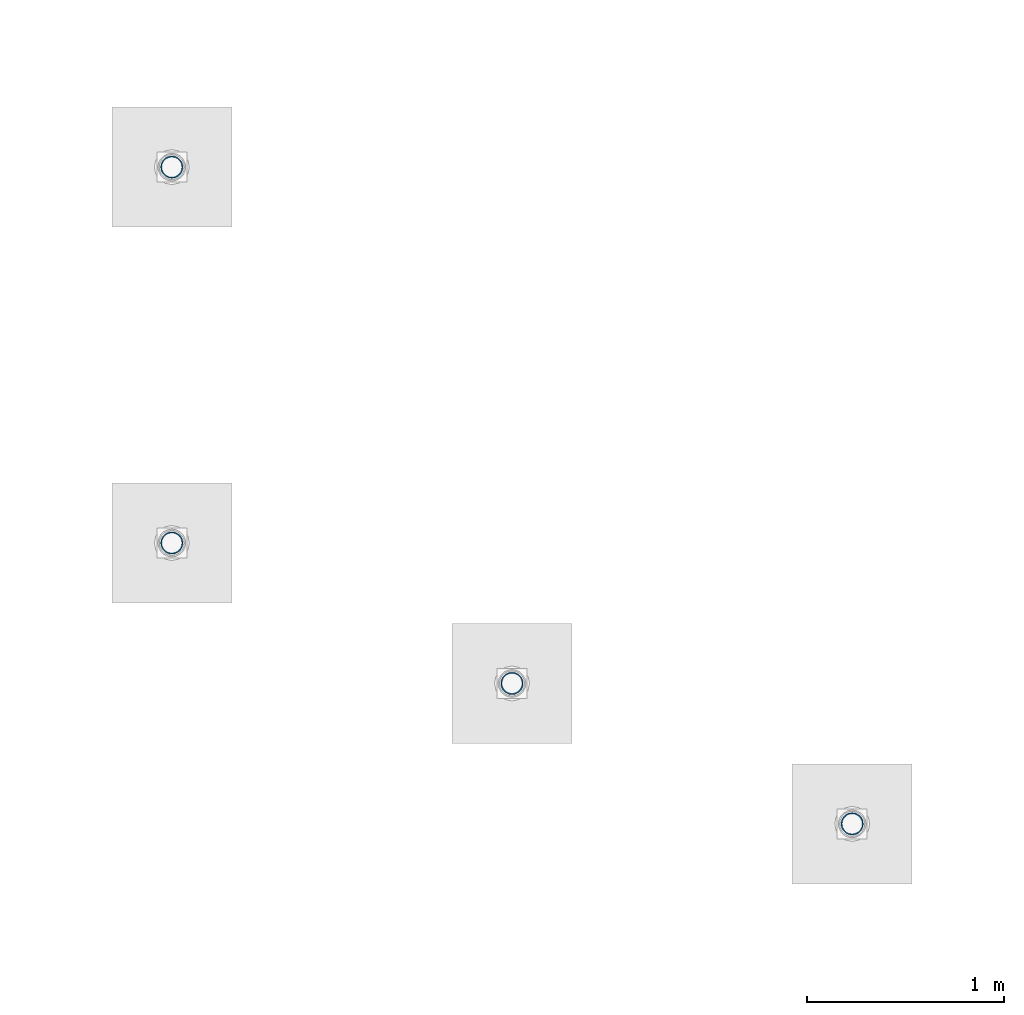
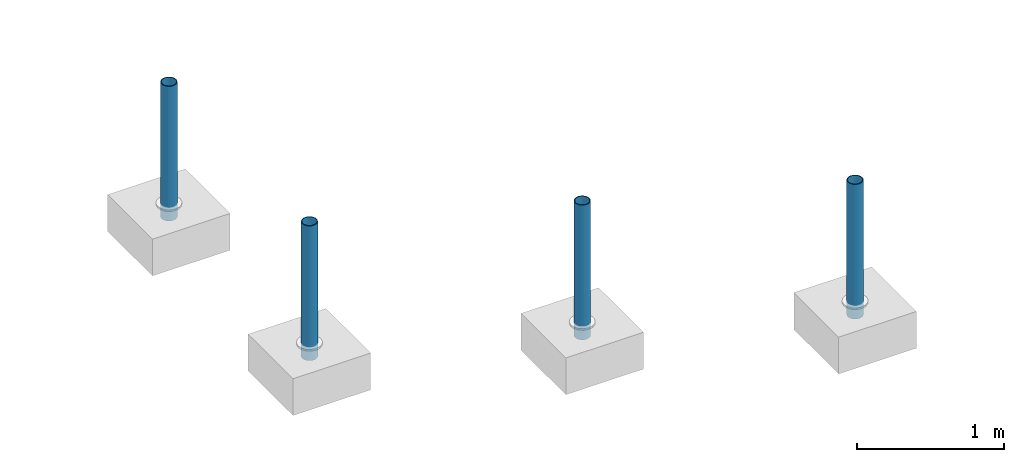
# One storey, part 1274 of 3843: 4 columns, 4 elements without a shape of their own.
"""IFC2X3 building model written with IfcOpenShell, lengths in millimetres."""

from ifc_helpers import new_model, si_unit, frame, origin_with_axes, place, context, subcontext, project, spatial, faceted_brep, material, type_object, element, aggregate, save


model = new_model("IFC2X3")

# Units and contexts
model_context = context("Model", 3, precision=1e-05, world=origin_with_axes())
body_context = subcontext(model_context, "Body", "Model", "MODEL_VIEW")
ifc_project = project(units=[si_unit("LENGTHUNIT", "METRE", prefix="MILLI"), si_unit("AREAUNIT", "SQUARE_METRE"), si_unit("VOLUMEUNIT", "CUBIC_METRE"), si_unit("MASSUNIT", "GRAM", prefix="KILO"), si_unit("TIMEUNIT", "SECOND"), si_unit("PLANEANGLEUNIT", "RADIAN"), si_unit("SOLIDANGLEUNIT", "STERADIAN"), si_unit("THERMODYNAMICTEMPERATUREUNIT", "DEGREE_CELSIUS"), si_unit("LUMINOUSINTENSITYUNIT", "LUMEN")], contexts=[model_context])

# Site, building, storey
site_placement = place(None, origin_with_axes())
site = spatial("IfcSite", under=ifc_project, at=site_placement, CompositionType="ELEMENT")
building_placement = place(site_placement, origin_with_axes())
building = spatial("IfcBuilding", under=site, at=building_placement, Name="Undefined", CompositionType="ELEMENT")
storey_placement = place(building_placement, origin_with_axes())
storey = spatial("IfcBuildingStorey", under=building, at=storey_placement, Name="Undefined", CompositionType="ELEMENT", Elevation=0.0)

# Assembly, column
assembly_1_placement = place(storey_placement, origin_with_axes())
assembly_1 = element("IfcElementAssembly", 1, at=assembly_1_placement, inside=storey, Name="PIPE_BOLLARD", AssemblyPlace="NOTDEFINED", PredefinedType="RIGID_FRAME")
ifc_material = material()
column_type = type_object("IfcColumnType", Name="PIPE4SCH40", PredefinedType="NOTDEFINED")
column_1_placement = place(assembly_1_placement, frame((-13010.053650111, 36218.2505800724, 30378.4), z_axis=(-1.0, 0.0, 0.0), x_axis=(0.0, 0.0, 1.0)))
column_1 = element("IfcColumn", 2, at=column_1_placement, type_object=column_type, material=ifc_material, Name="PIPE_BOLLARD", ObjectType="PIPE4SCH40", context=body_context, shape_type="Brep", body=[
    faceted_brep([(0.0, -51.1301999999996, 0.0), (0.0, -48.6277098894743, 15.8001007257844), (1117.6, -48.6277098894743, 15.8001007257844), (1117.6, -51.1301999999996, 0.0), (0.0, -41.3652007257897, 30.0535775067692), (1117.6, -41.3652007257897, 30.0535775067692), (0.0, -30.0535775067647, 41.3652007257915), (1117.6, -30.0535775067647, 41.3652007257915), (0.0, -15.8001007257899, 48.6277098894789), (1117.6, -15.8001007257899, 48.6277098894789), (0.0, 0.0, 51.1301999999996), (1117.6, 0.0, 51.1301999999996), (0.0, 15.8001007257899, 48.6277098894789), (1117.6, 15.8001007257899, 48.6277098894789), (0.0, 30.0535775067647, 41.3652007257915), (1117.6, 30.0535775067647, 41.3652007257915), (0.0, 41.3652007257897, 30.0535775067692), (1117.6, 41.3652007257897, 30.0535775067692), (0.0, 48.6277098894743, 15.8001007257844), (1117.6, 48.6277098894743, 15.8001007257844), (0.0, 51.1301999999996, 0.0), (1117.6, 51.1301999999996, 0.0), (0.0, 48.6277098894743, -15.8001007257844), (1117.6, 48.6277098894743, -15.8001007257844), (0.0, 41.3652007257897, -30.0535775067692), (1117.6, 41.3652007257897, -30.0535775067692), (0.0, 30.0535775067647, -41.3652007257915), (1117.6, 30.0535775067647, -41.3652007257915), (0.0, 15.8001007257899, -48.6277098894789), (1117.6, 15.8001007257899, -48.6277098894789), (0.0, 0.0, -51.1301999999996), (1117.6, 0.0, -51.1301999999996), (0.0, -15.8001007257899, -48.6277098894789), (1117.6, -15.8001007257899, -48.6277098894789), (0.0, -30.0535775067647, -41.3652007257915), (1117.6, -30.0535775067647, -41.3652007257915), (0.0, -41.3652007257897, -30.0535775067692), (1117.6, -41.3652007257897, -30.0535775067692), (0.0, -48.6277098894743, -15.8001007257844), (1117.6, -48.6277098894743, -15.8001007257844), (0.0, -57.1499999999996, 0.0), (0.0, -54.3528799062678, -17.6603212285263), (1117.6, -54.3528799062678, -17.6603212285263), (1117.6, -57.1499999999996, 0.0), (0.0, -46.2353212285279, -33.5919271685125), (1117.6, -46.2353212285279, -33.5919271685125), (0.0, -33.5919271685152, -46.2353212285234), (1117.6, -33.5919271685152, -46.2353212285234), (0.0, -17.6603212285281, -54.3528799062624), (1117.6, -17.6603212285281, -54.3528799062624), (0.0, 0.0, -57.1499999999942), (1117.6, 0.0, -57.1499999999942), (0.0, 17.6603212285281, -54.3528799062624), (1117.6, 17.6603212285281, -54.3528799062624), (0.0, 33.5919271685152, -46.2353212285234), (1117.6, 33.5919271685152, -46.2353212285234), (0.0, 46.2353212285279, -33.5919271685125), (1117.6, 46.2353212285279, -33.5919271685125), (0.0, 54.3528799062678, -17.6603212285263), (1117.6, 54.3528799062678, -17.6603212285263), (0.0, 57.1499999999996, 0.0), (1117.6, 57.1499999999996, 0.0), (0.0, 54.3528799062678, 17.6603212285263), (1117.6, 54.3528799062678, 17.6603212285263), (0.0, 46.2353212285279, 33.5919271685125), (1117.6, 46.2353212285279, 33.5919271685125), (0.0, 33.5919271685152, 46.2353212285234), (1117.6, 33.5919271685152, 46.2353212285234), (0.0, 17.6603212285281, 54.3528799062624), (1117.6, 17.6603212285281, 54.3528799062624), (0.0, 0.0, 57.1499999999942), (1117.6, 0.0, 57.1499999999942), (0.0, -17.6603212285281, 54.3528799062624), (1117.6, -17.6603212285281, 54.3528799062624), (0.0, -33.5919271685152, 46.2353212285234), (1117.6, -33.5919271685152, 46.2353212285234), (0.0, -46.2353212285279, 33.5919271685125), (1117.6, -46.2353212285279, 33.5919271685125), (0.0, -54.3528799062678, 17.6603212285263), (1117.6, -54.3528799062678, 17.6603212285263)], [[[0, 1, 2, 3]], [[1, 4, 5, 2]], [[4, 6, 7, 5]], [[6, 8, 9, 7]], [[8, 10, 11, 9]], [[10, 12, 13, 11]], [[12, 14, 15, 13]], [[14, 16, 17, 15]], [[16, 18, 19, 17]], [[18, 20, 21, 19]], [[20, 22, 23, 21]], [[22, 24, 25, 23]], [[24, 26, 27, 25]], [[26, 28, 29, 27]], [[28, 30, 31, 29]], [[30, 32, 33, 31]], [[32, 34, 35, 33]], [[34, 36, 37, 35]], [[36, 38, 39, 37]], [[38, 0, 3, 39]], [[40, 41, 42, 43]], [[41, 44, 45, 42]], [[44, 46, 47, 45]], [[46, 48, 49, 47]], [[48, 50, 51, 49]], [[50, 52, 53, 51]], [[52, 54, 55, 53]], [[54, 56, 57, 55]], [[56, 58, 59, 57]], [[58, 60, 61, 59]], [[60, 62, 63, 61]], [[62, 64, 65, 63]], [[64, 66, 67, 65]], [[66, 68, 69, 67]], [[68, 70, 71, 69]], [[70, 72, 73, 71]], [[72, 74, 75, 73]], [[74, 76, 77, 75]], [[76, 78, 79, 77]], [[78, 40, 43, 79]], [[45, 47, 49, 51, 53, 55, 57, 59, 61, 63, 65, 67, 69, 71, 73, 75, 77, 79, 43, 42], [5, 7, 9, 11, 13, 15, 17, 19, 21, 23, 25, 27, 29, 31, 33, 35, 37, 39, 3, 2]], [[78, 76, 74, 72, 70, 68, 66, 64, 62, 60, 58, 56, 54, 52, 50, 48, 46, 44, 41, 40], [38, 36, 34, 32, 30, 28, 26, 24, 22, 20, 18, 16, 14, 12, 10, 8, 6, 4, 1, 0]]]),
])
aggregate(assembly_1, [column_1])

assembly_2_placement = place(storey_placement, origin_with_axes())
assembly_2 = element("IfcElementAssembly", 3, at=assembly_2_placement, inside=storey, Name="PIPE_BOLLARD", AssemblyPlace="NOTDEFINED", PredefinedType="RIGID_FRAME")
column_2_placement = place(assembly_2_placement, frame((-14738.8916170299, 36932.010956049, 30378.4), z_axis=(-1.0, 0.0, 0.0), x_axis=(0.0, 0.0, 1.0)))
column_2 = element("IfcColumn", 4, at=column_2_placement, type_object=column_type, material=ifc_material, Name="PIPE_BOLLARD", ObjectType="PIPE4SCH40", context=body_context, shape_type="Brep", body=[
    faceted_brep([(0.0, -51.1301999999996, 0.0), (0.0, -48.6277098894743, 15.8001007257844), (1117.6, -48.6277098894743, 15.8001007257844), (1117.6, -51.1301999999996, 0.0), (0.0, -41.3652007257897, 30.0535775067692), (1117.6, -41.3652007257897, 30.0535775067692), (0.0, -30.0535775067647, 41.3652007257915), (1117.6, -30.0535775067647, 41.3652007257915), (0.0, -15.8001007257899, 48.6277098894789), (1117.6, -15.8001007257899, 48.6277098894789), (0.0, 0.0, 51.1301999999996), (1117.6, 0.0, 51.1301999999996), (0.0, 15.8001007257899, 48.6277098894789), (1117.6, 15.8001007257899, 48.6277098894789), (0.0, 30.0535775067647, 41.3652007257915), (1117.6, 30.0535775067647, 41.3652007257915), (0.0, 41.3652007257897, 30.0535775067692), (1117.6, 41.3652007257897, 30.0535775067692), (0.0, 48.6277098894743, 15.8001007257844), (1117.6, 48.6277098894743, 15.8001007257844), (0.0, 51.1301999999996, 0.0), (1117.6, 51.1301999999996, 0.0), (0.0, 48.6277098894743, -15.8001007257844), (1117.6, 48.6277098894743, -15.8001007257844), (0.0, 41.3652007257897, -30.0535775067692), (1117.6, 41.3652007257897, -30.0535775067692), (0.0, 30.0535775067647, -41.3652007257915), (1117.6, 30.0535775067647, -41.3652007257915), (0.0, 15.8001007257899, -48.6277098894789), (1117.6, 15.8001007257899, -48.6277098894789), (0.0, 0.0, -51.1301999999996), (1117.6, 0.0, -51.1301999999996), (0.0, -15.8001007257899, -48.6277098894789), (1117.6, -15.8001007257899, -48.6277098894789), (0.0, -30.0535775067647, -41.3652007257915), (1117.6, -30.0535775067647, -41.3652007257915), (0.0, -41.3652007257897, -30.0535775067692), (1117.6, -41.3652007257897, -30.0535775067692), (0.0, -48.6277098894743, -15.8001007257844), (1117.6, -48.6277098894743, -15.8001007257844), (0.0, -57.1499999999996, 0.0), (0.0, -54.3528799062678, -17.6603212285263), (1117.6, -54.3528799062678, -17.6603212285263), (1117.6, -57.1499999999996, 0.0), (0.0, -46.2353212285279, -33.5919271685125), (1117.6, -46.2353212285279, -33.5919271685125), (0.0, -33.5919271685152, -46.2353212285234), (1117.6, -33.5919271685152, -46.2353212285234), (0.0, -17.6603212285281, -54.3528799062624), (1117.6, -17.6603212285281, -54.3528799062624), (0.0, 0.0, -57.1499999999942), (1117.6, 0.0, -57.1499999999942), (0.0, 17.6603212285281, -54.3528799062624), (1117.6, 17.6603212285281, -54.3528799062624), (0.0, 33.5919271685152, -46.2353212285234), (1117.6, 33.5919271685152, -46.2353212285234), (0.0, 46.2353212285279, -33.5919271685125), (1117.6, 46.2353212285279, -33.5919271685125), (0.0, 54.3528799062678, -17.6603212285263), (1117.6, 54.3528799062678, -17.6603212285263), (0.0, 57.1499999999996, 0.0), (1117.6, 57.1499999999996, 0.0), (0.0, 54.3528799062678, 17.6603212285263), (1117.6, 54.3528799062678, 17.6603212285263), (0.0, 46.2353212285279, 33.5919271685125), (1117.6, 46.2353212285279, 33.5919271685125), (0.0, 33.5919271685152, 46.2353212285234), (1117.6, 33.5919271685152, 46.2353212285234), (0.0, 17.6603212285281, 54.3528799062624), (1117.6, 17.6603212285281, 54.3528799062624), (0.0, 0.0, 57.1499999999942), (1117.6, 0.0, 57.1499999999942), (0.0, -17.6603212285281, 54.3528799062624), (1117.6, -17.6603212285281, 54.3528799062624), (0.0, -33.5919271685152, 46.2353212285234), (1117.6, -33.5919271685152, 46.2353212285234), (0.0, -46.2353212285279, 33.5919271685125), (1117.6, -46.2353212285279, 33.5919271685125), (0.0, -54.3528799062678, 17.6603212285263), (1117.6, -54.3528799062678, 17.6603212285263)], [[[0, 1, 2, 3]], [[1, 4, 5, 2]], [[4, 6, 7, 5]], [[6, 8, 9, 7]], [[8, 10, 11, 9]], [[10, 12, 13, 11]], [[12, 14, 15, 13]], [[14, 16, 17, 15]], [[16, 18, 19, 17]], [[18, 20, 21, 19]], [[20, 22, 23, 21]], [[22, 24, 25, 23]], [[24, 26, 27, 25]], [[26, 28, 29, 27]], [[28, 30, 31, 29]], [[30, 32, 33, 31]], [[32, 34, 35, 33]], [[34, 36, 37, 35]], [[36, 38, 39, 37]], [[38, 0, 3, 39]], [[40, 41, 42, 43]], [[41, 44, 45, 42]], [[44, 46, 47, 45]], [[46, 48, 49, 47]], [[48, 50, 51, 49]], [[50, 52, 53, 51]], [[52, 54, 55, 53]], [[54, 56, 57, 55]], [[56, 58, 59, 57]], [[58, 60, 61, 59]], [[60, 62, 63, 61]], [[62, 64, 65, 63]], [[64, 66, 67, 65]], [[66, 68, 69, 67]], [[68, 70, 71, 69]], [[70, 72, 73, 71]], [[72, 74, 75, 73]], [[74, 76, 77, 75]], [[76, 78, 79, 77]], [[78, 40, 43, 79]], [[45, 47, 49, 51, 53, 55, 57, 59, 61, 63, 65, 67, 69, 71, 73, 75, 77, 79, 43, 42], [5, 7, 9, 11, 13, 15, 17, 19, 21, 23, 25, 27, 29, 31, 33, 35, 37, 39, 3, 2]], [[78, 76, 74, 72, 70, 68, 66, 64, 62, 60, 58, 56, 54, 52, 50, 48, 46, 44, 41, 40], [38, 36, 34, 32, 30, 28, 26, 24, 22, 20, 18, 16, 14, 12, 10, 8, 6, 4, 1, 0]]]),
])
aggregate(assembly_2, [column_2])

assembly_3_placement = place(storey_placement, origin_with_axes())
assembly_3 = element("IfcElementAssembly", 5, at=assembly_3_placement, inside=storey, Name="PIPE_BOLLARD", AssemblyPlace="NOTDEFINED", PredefinedType="RIGID_FRAME")
column_3_placement = place(assembly_3_placement, frame((-16467.7314912975, 37645.7789614201, 30378.4), z_axis=(-1.0, 0.0, 0.0), x_axis=(0.0, 0.0, 1.0)))
column_3 = element("IfcColumn", 6, at=column_3_placement, type_object=column_type, material=ifc_material, Name="PIPE_BOLLARD", ObjectType="PIPE4SCH40", context=body_context, shape_type="Brep", body=[
    faceted_brep([(0.0, -51.1301999999996, 0.0), (0.0, -48.6277098894743, 15.8001007257844), (1117.6, -48.6277098894743, 15.8001007257844), (1117.6, -51.1301999999996, 0.0), (0.0, -41.3652007257897, 30.0535775067692), (1117.6, -41.3652007257897, 30.0535775067692), (0.0, -30.0535775067647, 41.3652007257915), (1117.6, -30.0535775067647, 41.3652007257915), (0.0, -15.8001007257899, 48.6277098894789), (1117.6, -15.8001007257899, 48.6277098894789), (0.0, 0.0, 51.1301999999996), (1117.6, 0.0, 51.1301999999996), (0.0, 15.8001007257899, 48.6277098894789), (1117.6, 15.8001007257899, 48.6277098894789), (0.0, 30.0535775067647, 41.3652007257915), (1117.6, 30.0535775067647, 41.3652007257915), (0.0, 41.3652007257897, 30.0535775067692), (1117.6, 41.3652007257897, 30.0535775067692), (0.0, 48.6277098894743, 15.8001007257844), (1117.6, 48.6277098894743, 15.8001007257844), (0.0, 51.1301999999996, 0.0), (1117.6, 51.1301999999996, 0.0), (0.0, 48.6277098894743, -15.8001007257844), (1117.6, 48.6277098894743, -15.8001007257844), (0.0, 41.3652007257897, -30.0535775067692), (1117.6, 41.3652007257897, -30.0535775067692), (0.0, 30.0535775067647, -41.3652007257915), (1117.6, 30.0535775067647, -41.3652007257915), (0.0, 15.8001007257899, -48.6277098894789), (1117.6, 15.8001007257899, -48.6277098894789), (0.0, 0.0, -51.1301999999996), (1117.6, 0.0, -51.1301999999996), (0.0, -15.8001007257899, -48.6277098894789), (1117.6, -15.8001007257899, -48.6277098894789), (0.0, -30.0535775067647, -41.3652007257915), (1117.6, -30.0535775067647, -41.3652007257915), (0.0, -41.3652007257897, -30.0535775067692), (1117.6, -41.3652007257897, -30.0535775067692), (0.0, -48.6277098894743, -15.8001007257844), (1117.6, -48.6277098894743, -15.8001007257844), (0.0, -57.1499999999996, 0.0), (0.0, -54.3528799062678, -17.6603212285263), (1117.6, -54.3528799062678, -17.6603212285263), (1117.6, -57.1499999999996, 0.0), (0.0, -46.2353212285279, -33.5919271685125), (1117.6, -46.2353212285279, -33.5919271685125), (0.0, -33.5919271685152, -46.2353212285234), (1117.6, -33.5919271685152, -46.2353212285234), (0.0, -17.6603212285281, -54.3528799062624), (1117.6, -17.6603212285281, -54.3528799062624), (0.0, 0.0, -57.1499999999942), (1117.6, 0.0, -57.1499999999942), (0.0, 17.6603212285281, -54.3528799062624), (1117.6, 17.6603212285281, -54.3528799062624), (0.0, 33.5919271685152, -46.2353212285234), (1117.6, 33.5919271685152, -46.2353212285234), (0.0, 46.2353212285279, -33.5919271685125), (1117.6, 46.2353212285279, -33.5919271685125), (0.0, 54.3528799062678, -17.6603212285263), (1117.6, 54.3528799062678, -17.6603212285263), (0.0, 57.1499999999996, 0.0), (1117.6, 57.1499999999996, 0.0), (0.0, 54.3528799062678, 17.6603212285263), (1117.6, 54.3528799062678, 17.6603212285263), (0.0, 46.2353212285279, 33.5919271685125), (1117.6, 46.2353212285279, 33.5919271685125), (0.0, 33.5919271685152, 46.2353212285234), (1117.6, 33.5919271685152, 46.2353212285234), (0.0, 17.6603212285281, 54.3528799062624), (1117.6, 17.6603212285281, 54.3528799062624), (0.0, 0.0, 57.1499999999942), (1117.6, 0.0, 57.1499999999942), (0.0, -17.6603212285281, 54.3528799062624), (1117.6, -17.6603212285281, 54.3528799062624), (0.0, -33.5919271685152, 46.2353212285234), (1117.6, -33.5919271685152, 46.2353212285234), (0.0, -46.2353212285279, 33.5919271685125), (1117.6, -46.2353212285279, 33.5919271685125), (0.0, -54.3528799062678, 17.6603212285263), (1117.6, -54.3528799062678, 17.6603212285263)], [[[0, 1, 2, 3]], [[1, 4, 5, 2]], [[4, 6, 7, 5]], [[6, 8, 9, 7]], [[8, 10, 11, 9]], [[10, 12, 13, 11]], [[12, 14, 15, 13]], [[14, 16, 17, 15]], [[16, 18, 19, 17]], [[18, 20, 21, 19]], [[20, 22, 23, 21]], [[22, 24, 25, 23]], [[24, 26, 27, 25]], [[26, 28, 29, 27]], [[28, 30, 31, 29]], [[30, 32, 33, 31]], [[32, 34, 35, 33]], [[34, 36, 37, 35]], [[36, 38, 39, 37]], [[38, 0, 3, 39]], [[40, 41, 42, 43]], [[41, 44, 45, 42]], [[44, 46, 47, 45]], [[46, 48, 49, 47]], [[48, 50, 51, 49]], [[50, 52, 53, 51]], [[52, 54, 55, 53]], [[54, 56, 57, 55]], [[56, 58, 59, 57]], [[58, 60, 61, 59]], [[60, 62, 63, 61]], [[62, 64, 65, 63]], [[64, 66, 67, 65]], [[66, 68, 69, 67]], [[68, 70, 71, 69]], [[70, 72, 73, 71]], [[72, 74, 75, 73]], [[74, 76, 77, 75]], [[76, 78, 79, 77]], [[78, 40, 43, 79]], [[45, 47, 49, 51, 53, 55, 57, 59, 61, 63, 65, 67, 69, 71, 73, 75, 77, 79, 43, 42], [5, 7, 9, 11, 13, 15, 17, 19, 21, 23, 25, 27, 29, 31, 33, 35, 37, 39, 3, 2]], [[78, 76, 74, 72, 70, 68, 66, 64, 62, 60, 58, 56, 54, 52, 50, 48, 46, 44, 41, 40], [38, 36, 34, 32, 30, 28, 26, 24, 22, 20, 18, 16, 14, 12, 10, 8, 6, 4, 1, 0]]]),
])
aggregate(assembly_3, [column_3])

assembly_4_placement = place(storey_placement, origin_with_axes())
assembly_4 = element("IfcElementAssembly", 7, at=assembly_4_placement, inside=storey, Name="PIPE_BOLLARD", AssemblyPlace="NOTDEFINED", PredefinedType="RIGID_FRAME")
column_4_placement = place(assembly_4_placement, frame((-16467.7257692516, 39556.0992434025, 30378.4), z_axis=(-1.0, 0.0, 0.0), x_axis=(0.0, 0.0, 1.0)))
column_4 = element("IfcColumn", 8, at=column_4_placement, type_object=column_type, material=ifc_material, Name="PIPE_BOLLARD", ObjectType="PIPE4SCH40", context=body_context, shape_type="Brep", body=[
    faceted_brep([(0.0, -51.1301999999996, 0.0), (0.0, -48.6277098894743, 15.8001007257844), (1117.6, -48.6277098894743, 15.8001007257844), (1117.6, -51.1301999999996, 0.0), (0.0, -41.3652007257897, 30.0535775067692), (1117.6, -41.3652007257897, 30.0535775067692), (0.0, -30.0535775067647, 41.3652007257915), (1117.6, -30.0535775067647, 41.3652007257915), (0.0, -15.8001007257899, 48.6277098894789), (1117.6, -15.8001007257899, 48.6277098894789), (0.0, 0.0, 51.1301999999996), (1117.6, 0.0, 51.1301999999996), (0.0, 15.8001007257899, 48.6277098894789), (1117.6, 15.8001007257899, 48.6277098894789), (0.0, 30.0535775067647, 41.3652007257915), (1117.6, 30.0535775067647, 41.3652007257915), (0.0, 41.3652007257897, 30.0535775067692), (1117.6, 41.3652007257897, 30.0535775067692), (0.0, 48.6277098894743, 15.8001007257844), (1117.6, 48.6277098894743, 15.8001007257844), (0.0, 51.1301999999996, 0.0), (1117.6, 51.1301999999996, 0.0), (0.0, 48.6277098894743, -15.8001007257844), (1117.6, 48.6277098894743, -15.8001007257844), (0.0, 41.3652007257897, -30.0535775067692), (1117.6, 41.3652007257897, -30.0535775067692), (0.0, 30.0535775067647, -41.3652007257915), (1117.6, 30.0535775067647, -41.3652007257915), (0.0, 15.8001007257899, -48.6277098894789), (1117.6, 15.8001007257899, -48.6277098894789), (0.0, 0.0, -51.1301999999996), (1117.6, 0.0, -51.1301999999996), (0.0, -15.8001007257899, -48.6277098894789), (1117.6, -15.8001007257899, -48.6277098894789), (0.0, -30.0535775067647, -41.3652007257915), (1117.6, -30.0535775067647, -41.3652007257915), (0.0, -41.3652007257897, -30.0535775067692), (1117.6, -41.3652007257897, -30.0535775067692), (0.0, -48.6277098894743, -15.8001007257844), (1117.6, -48.6277098894743, -15.8001007257844), (0.0, -57.1499999999996, 0.0), (0.0, -54.3528799062678, -17.6603212285263), (1117.6, -54.3528799062678, -17.6603212285263), (1117.6, -57.1499999999996, 0.0), (0.0, -46.2353212285279, -33.5919271685125), (1117.6, -46.2353212285279, -33.5919271685125), (0.0, -33.5919271685152, -46.2353212285234), (1117.6, -33.5919271685152, -46.2353212285234), (0.0, -17.6603212285281, -54.3528799062624), (1117.6, -17.6603212285281, -54.3528799062624), (0.0, 0.0, -57.1499999999942), (1117.6, 0.0, -57.1499999999942), (0.0, 17.6603212285281, -54.3528799062624), (1117.6, 17.6603212285281, -54.3528799062624), (0.0, 33.5919271685152, -46.2353212285234), (1117.6, 33.5919271685152, -46.2353212285234), (0.0, 46.2353212285279, -33.5919271685125), (1117.6, 46.2353212285279, -33.5919271685125), (0.0, 54.3528799062678, -17.6603212285263), (1117.6, 54.3528799062678, -17.6603212285263), (0.0, 57.1499999999996, 0.0), (1117.6, 57.1499999999996, 0.0), (0.0, 54.3528799062678, 17.6603212285263), (1117.6, 54.3528799062678, 17.6603212285263), (0.0, 46.2353212285279, 33.5919271685125), (1117.6, 46.2353212285279, 33.5919271685125), (0.0, 33.5919271685152, 46.2353212285234), (1117.6, 33.5919271685152, 46.2353212285234), (0.0, 17.6603212285281, 54.3528799062624), (1117.6, 17.6603212285281, 54.3528799062624), (0.0, 0.0, 57.1499999999942), (1117.6, 0.0, 57.1499999999942), (0.0, -17.6603212285281, 54.3528799062624), (1117.6, -17.6603212285281, 54.3528799062624), (0.0, -33.5919271685152, 46.2353212285234), (1117.6, -33.5919271685152, 46.2353212285234), (0.0, -46.2353212285279, 33.5919271685125), (1117.6, -46.2353212285279, 33.5919271685125), (0.0, -54.3528799062678, 17.6603212285263), (1117.6, -54.3528799062678, 17.6603212285263)], [[[0, 1, 2, 3]], [[1, 4, 5, 2]], [[4, 6, 7, 5]], [[6, 8, 9, 7]], [[8, 10, 11, 9]], [[10, 12, 13, 11]], [[12, 14, 15, 13]], [[14, 16, 17, 15]], [[16, 18, 19, 17]], [[18, 20, 21, 19]], [[20, 22, 23, 21]], [[22, 24, 25, 23]], [[24, 26, 27, 25]], [[26, 28, 29, 27]], [[28, 30, 31, 29]], [[30, 32, 33, 31]], [[32, 34, 35, 33]], [[34, 36, 37, 35]], [[36, 38, 39, 37]], [[38, 0, 3, 39]], [[40, 41, 42, 43]], [[41, 44, 45, 42]], [[44, 46, 47, 45]], [[46, 48, 49, 47]], [[48, 50, 51, 49]], [[50, 52, 53, 51]], [[52, 54, 55, 53]], [[54, 56, 57, 55]], [[56, 58, 59, 57]], [[58, 60, 61, 59]], [[60, 62, 63, 61]], [[62, 64, 65, 63]], [[64, 66, 67, 65]], [[66, 68, 69, 67]], [[68, 70, 71, 69]], [[70, 72, 73, 71]], [[72, 74, 75, 73]], [[74, 76, 77, 75]], [[76, 78, 79, 77]], [[78, 40, 43, 79]], [[45, 47, 49, 51, 53, 55, 57, 59, 61, 63, 65, 67, 69, 71, 73, 75, 77, 79, 43, 42], [5, 7, 9, 11, 13, 15, 17, 19, 21, 23, 25, 27, 29, 31, 33, 35, 37, 39, 3, 2]], [[78, 76, 74, 72, 70, 68, 66, 64, 62, 60, 58, 56, 54, 52, 50, 48, 46, 44, 41, 40], [38, 36, 34, 32, 30, 28, 26, 24, 22, 20, 18, 16, 14, 12, 10, 8, 6, 4, 1, 0]]]),
])
aggregate(assembly_4, [column_4])

save(model, "model.ifc")
